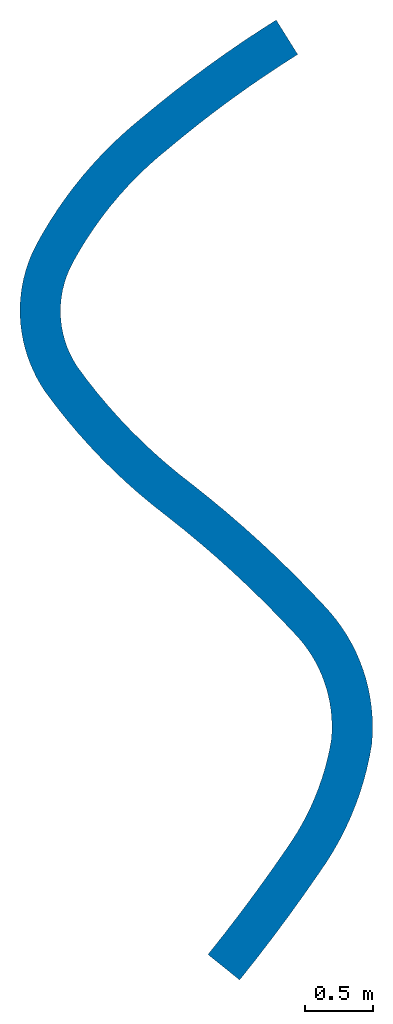
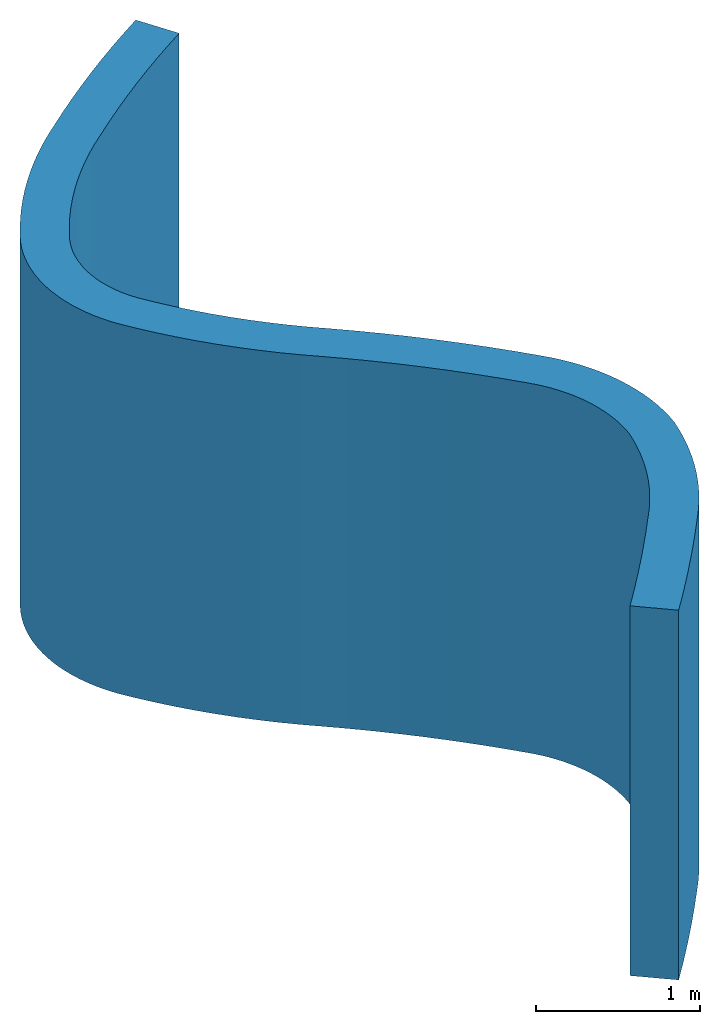
# Not in any storey: 1 wall.
"""IFC2X3 building model written with IfcOpenShell, lengths in metres."""

from ifc_helpers import new_model, si_unit, point, direction, frame, frame_2d, origin_with_axes, place, context, project, spatial, polyline, circle_curve, parameter, trimmed, segment, composite_curve, outline, extrude, material, layer, layer_set, layer_usage, type_object, element, save


model = new_model("IFC2X3")

# Units and contexts
model_context = context("Model", 3, precision=1e-05, world=origin_with_axes(), true_north=direction((0.0, 1.0)), identifier="Body")
ifc_project = project(units=[si_unit("LENGTHUNIT", "METRE"), si_unit("AREAUNIT", "SQUARE_METRE"), si_unit("VOLUMEUNIT", "CUBIC_METRE"), si_unit("PLANEANGLEUNIT", "RADIAN")], contexts=[model_context])

# Building
building_placement = place(None, origin_with_axes())
building = spatial("IfcBuilding", under=ifc_project, at=building_placement, CompositionType="ELEMENT")

# Wall
ifc_material = material(Name="Masonry")
ifc_layer = layer(ifc_material, 0.3, ventilated=True)
ifc_layer_set = layer_set([ifc_layer], Name="Masonry 300")
ifc_layer_usage = layer_usage(ifc_layer_set, "AXIS2", "NEGATIVE", -0.15)
wall_type = type_object("IfcWallType", Name="Masonry 300", PredefinedType="STANDARD", material=ifc_material)
wall_placement = place(None, frame((0.633000000001003, -0.205999999998753, 0.0), z_axis=(0.0, 0.0, 1.0), x_axis=(0.62704761, 0.77898094, 0.0)))
element("IfcWall", 1, at=wall_placement, inside=building, type_object=wall_type, material=ifc_layer_usage, context=model_context, shape_type="SweptSolid", body=[
    extrude(outline(composite_curve([segment(composite_curve([segment(trimmed(circle_curve(frame_2d((0.0, 12.5906721777929), x_axis=(0.0, -1.0)), 12.7406721777929), [parameter(0.0), point((0.0, -12.7406721777929))], [parameter(0.0779576017017681), point((0.992226509809783, -0.111304601244954))], True, "PARAMETER"), True, "CONTINUOUS"), segment(trimmed(circle_curve(frame_2d((0.858404826729998, 2.10421523903142), x_axis=(0.06029205, -0.99818078)), 2.21955770493145), [parameter(0.0), point((0.992226509809783, -2.21551984027638))], [parameter(0.461883740141353), point((1.96551768886992, 0.180485134259726))], True, "PARAMETER"), True, "CONTINUOUS")], self_intersect="UNKNOWN"), True, "CONTINUOUS"), segment(composite_curve([segment(composite_curve([segment(trimmed(circle_curve(frame_2d((1.24081001154631, 1.28335586960837), x_axis=(0.54915886, -0.83571798)), 1.31966854795446), [parameter(0.0), point((1.96551768886992, -1.10287073534864))], [parameter(0.210395964566149), point((2.17986805807303, 0.356158446341))], True, "PARAMETER"), True, "CONTINUOUS"), segment(trimmed(circle_curve(frame_2d((1.25166797507066, 1.27270454282025), x_axis=(0.71155965, -0.70262569)), 1.30445856241468), [parameter(0.0), point((2.17986805807303, -0.916546096479253))], [parameter(0.217081000384491), point((2.35548923034152, 0.577585288685234))], True, "PARAMETER"), True, "CONTINUOUS"), segment(trimmed(circle_curve(frame_2d((1.26571961381282, 1.26385603475642), x_axis=(0.846191, -0.53287972)), 1.28785300171339), [parameter(0.0), point((2.35548923034152, -0.686270746071181))], [parameter(0.218962834308345), point((2.47853899461762, 0.830688049366832))], True, "PARAMETER"), True, "CONTINUOUS"), segment(trimmed(circle_curve(frame_2d((1.27944446196939, 1.25890136073525), x_axis=(0.94175055, -0.3363122)), 1.27326130007158), [parameter(0.0), point((2.47853899461762, -0.428213311368416))], [parameter(0.215533275911176), point((2.54237621759732, 1.09704426670928))], True, "PARAMETER"), True, "CONTINUOUS")], self_intersect="UNKNOWN"), True, "CONTINUOUS"), segment(trimmed(circle_curve(frame_2d((-5.55050895259021, 2.28926282452048), x_axis=(0.98932235, -0.14574388)), 8.18023077103761), [parameter(0.0), point((2.54237621759732, -1.1922185578112))], [parameter(0.162755126513052), point((2.62860962012269, 2.42415107802535))], True, "PARAMETER"), True, "CONTINUOUS")], self_intersect="UNKNOWN"), True, "CONTINUOUS"), segment(composite_curve([segment(composite_curve([segment(trimmed(circle_curve(frame_2d((6.69562431221205, 2.53857517679835), x_axis=(-0.99276605, 0.12006484)), 4.06862401556727), [parameter(0.148482437366474), point((2.62860962012269, -0.114424098773002))], [parameter(0.0), point((2.65643250932397, 3.02707385594955))], False, "PARAMETER"), True, "CONTINUOUS"), segment(trimmed(circle_curve(frame_2d((6.67815815953575, 2.54068853966872), x_axis=(-0.96396513, 0.26602864)), 4.05103047155474), [parameter(0.148915910057531), point((2.65643250932397, 0.486385316280828))], [parameter(0.0), point((2.77310605905153, 3.6183786500292))], False, "PARAMETER"), True, "CONTINUOUS")], self_intersect="UNKNOWN"), True, "CONTINUOUS"), segment(trimmed(circle_curve(frame_2d((3.48219434932468, 3.39533102562583), x_axis=(-0.17757929, 0.9841065)), 0.743341406188621), [parameter(1.08751382659747), point((2.77310605905153, 0.223047624403365))], [parameter(0.0), point((3.3501923089331, 4.12685813208665))], False, "PARAMETER"), True, "CONTINUOUS")], self_intersect="UNKNOWN"), True, "CONTINUOUS"), segment(trimmed(circle_curve(frame_2d((3.84553509688989, 1.42371524424486), x_axis=(0.21751573, 0.97605682)), 2.74815318890168), [parameter(0.400504770798192), point((3.3501923089331, 2.70314288784179))], [parameter(0.0), point((4.4433016485376, 4.10606889344954))], False, "PARAMETER"), True, "CONTINUOUS"), segment(composite_curve([segment(trimmed(circle_curve(frame_2d((2.81851394213364, -4.20008417101934), x_axis=(0.26033035, 0.96551961)), 8.46357571132126), [parameter(0.0701910239030213), point((4.4433016485376, 8.30615306446888))], [parameter(0.0), point((5.02183957904783, 3.97166410942738))], False, "PARAMETER"), True, "CONTINUOUS"), segment(trimmed(circle_curve(frame_2d((2.84031506383951, -4.11924426569001), x_axis=(0.32784513, 0.94473148)), 8.37984770416501), [parameter(0.0706579165746258), point((5.02183957904783, 8.09090837511739))], [parameter(0.0), point((5.5876073216265, 3.79746166514406))], False, "PARAMETER"), True, "CONTINUOUS")], self_intersect="UNKNOWN"), True, "CONTINUOUS"), segment(polyline([(5.5876073216265, 3.79746166514406), (5.68597746420469, 4.08087534697531)]), True, "CONTINUOUS"), segment(composite_curve([segment(composite_curve([segment(trimmed(circle_curve(frame_2d((2.83955778650122, -4.12170794281741), x_axis=(0.327837, 0.9447343)), 8.68242348699971), [parameter(0.0), point((5.68597746420469, 8.20258328979272))], [parameter(0.0704156823942545), point((5.10181028065729, 4.26081502227424))], True, "PARAMETER"), True, "CONTINUOUS"), segment(trimmed(circle_curve(frame_2d((2.81798638223099, -4.20235808813424), x_axis=(0.26053477, 0.96546447)), 8.76590843528292), [parameter(0.0), point((5.10181028065729, 8.46317311040848))], [parameter(0.0699524375157497), point((4.5046879109871, 4.39974564575877))], True, "PARAMETER"), True, "CONTINUOUS")], self_intersect="UNKNOWN"), True, "CONTINUOUS"), segment(trimmed(circle_curve(frame_2d((3.8455356273326, 1.42370648390197), x_axis=(0.21624583, 0.97633895)), 3.04816187659912), [parameter(0.0), point((4.5046879109871, 2.9760391618568))], [parameter(0.399074273372537), point((3.29650622679579, 4.42201559793582))], True, "PARAMETER"), True, "CONTINUOUS"), segment(composite_curve([segment(trimmed(circle_curve(frame_2d((3.48010213034506, 3.40810517356184), x_axis=(-0.17817945, 0.98399801)), 1.03039885697448), [parameter(0.0), point((3.29650622679579, 1.01391042437399))], [parameter(0.270346117676781), point((3.03239471575158, 4.33615682911358))], True, "PARAMETER"), True, "CONTINUOUS"), segment(trimmed(circle_curve(frame_2d((3.48598078250791, 3.39613776733709), x_axis=(-0.43458104, 0.90063273)), 1.04373184125935), [parameter(0.0), point((3.03239471575158, 0.940019061776487))], [parameter(0.278361050439085), point((2.79155598268534, 4.17533630035035))], True, "PARAMETER"), True, "CONTINUOUS"), segment(trimmed(circle_curve(frame_2d((3.49676473529358, 3.38403407997117), x_axis=(-0.66532722, 0.74655186)), 1.05994272898694), [parameter(0.0), point((2.79155598268534, 0.791302220379178))], [parameter(0.275559056415503), point((2.60285980534036, 3.95360634486617))], True, "PARAMETER"), True, "CONTINUOUS"), segment(trimmed(circle_curve(frame_2d((3.50838196430836, 3.37651721255897), x_axis=(-0.8433037, 0.53743732)), 1.07377942195273), [parameter(0.0), point((2.60285980534036, 0.577089132307195))], [parameter(0.263140403514809), point((2.48392076033443, 3.69820260010621))], True, "PARAMETER"), True, "CONTINUOUS")], self_intersect="UNKNOWN"), True, "CONTINUOUS")], self_intersect="UNKNOWN"), True, "CONTINUOUS"), segment(composite_curve([segment(composite_curve([segment(trimmed(circle_curve(frame_2d((6.67814622326416, 2.54069120373496), x_axis=(-0.96396412, 0.2660323)), 4.35101825629558), [parameter(0.0), point((2.48392076033443, 1.15751139637125))], [parameter(0.14871027942696), point((2.35871237809326, 3.06399907087401))], True, "PARAMETER"), True, "CONTINUOUS"), segment(trimmed(circle_curve(frame_2d((6.69558814572964, 2.5385771433756), x_axis=(-0.99274089, 0.12027272)), 4.36858782970055), [parameter(0.0), point((2.35871237809326, 0.525421927498412))], [parameter(0.148280353735435), point((2.32867810374149, 2.417513891351))], True, "PARAMETER"), True, "CONTINUOUS")], self_intersect="UNKNOWN"), True, "CONTINUOUS"), segment(composite_curve([segment(trimmed(circle_curve(frame_2d((-5.53722086560982, 2.29018971445617), x_axis=(0.99786202, -0.0653559)), 7.8669293909418), [parameter(0.081587954383697), point((2.32867810374149, 0.127324176894835))], [parameter(0.0), point((2.31288917194865, 1.77603950266238))], False, "PARAMETER"), True, "CONTINUOUS"), segment(trimmed(circle_curve(frame_2d((-5.64214815642544, 2.29705402330002), x_axis=(0.98932158, -0.14574913)), 7.97208097215153), [parameter(0.0808686387395047), point((2.31288917194865, -0.521014520637636))], [parameter(0.0), point((2.24480359373925, 1.13513013718928))], False, "PARAMETER"), True, "CONTINUOUS")], self_intersect="UNKNOWN"), True, "CONTINUOUS")], self_intersect="UNKNOWN"), True, "CONTINUOUS"), segment(composite_curve([segment(composite_curve([segment(trimmed(circle_curve(frame_2d((1.27950974863352, 1.2588883080951), x_axis=(0.94248197, -0.33425699)), 0.973194889148593), [parameter(0.213304607056117), point((2.24480359373925, -0.12375817090581))], [parameter(0.0), point((2.19672838578957, 0.933591114872435))], False, "PARAMETER"), True, "CONTINUOUS"), segment(trimmed(circle_curve(frame_2d((1.26594460088601, 1.26375079203904), x_axis=(0.84853767, -0.52913497)), 0.987605116767915), [parameter(0.216714878696181), point((2.19672838578957, -0.330159677166606))], [parameter(0.0), point((2.10396474631296, 0.741174383726576))], False, "PARAMETER"), True, "CONTINUOUS"), segment(trimmed(circle_curve(frame_2d((1.25200029259022, 1.27244616790671), x_axis=(0.71613222, -0.69796464)), 1.0040384151381), [parameter(0.214970646318693), point((2.10396474631296, -0.531271784180138))], [parameter(0.0), point((1.97102455457684, 0.571662856356253))], False, "PARAMETER"), True, "CONTINUOUS"), segment(trimmed(circle_curve(frame_2d((1.24111797301021, 1.28298529850649), x_axis=(0.55614796, -0.83108329)), 1.0191875364823), [parameter(0.208548481379479), point((1.97102455457684, -0.711322442150237))], [parameter(0.0), point((1.80793704571323, 0.435955562699688))], False, "PARAMETER"), True, "CONTINUOUS")], self_intersect="UNKNOWN"), True, "CONTINUOUS"), segment(composite_curve([segment(trimmed(circle_curve(frame_2d((0.865464974174703, 2.0921263494107), x_axis=(0.39166325, -0.92010864)), 1.90555904668029), [parameter(0.114925447323616), point((1.80793704571324, -1.65617078671101))], [parameter(0.0), point((1.61180241808548, 0.338805015427155))], False, "PARAMETER"), True, "CONTINUOUS"), segment(trimmed(circle_curve(frame_2d((0.858778212823704, 2.10785247811792), x_axis=(0.28351238, -0.95896858)), 1.92264775217999), [parameter(0.114980228431338), point((1.61180241808548, -1.76904746269077))], [parameter(0.0), point((1.40387264694797, 0.264093698654212))], False, "PARAMETER"), True, "CONTINUOUS"), segment(trimmed(circle_curve(frame_2d((0.853767680723008, 2.12479514090241), x_axis=(0.1723241, -0.98504031)), 1.94031578127115), [parameter(0.114266986281034), point((1.40387264694797, -1.86070144224819))], [parameter(0.0), point((1.18813084735411, 0.213505889153654))], False, "PARAMETER"), True, "CONTINUOUS"), segment(trimmed(circle_curve(frame_2d((0.850791973837679, 2.14174954891179), x_axis=(0.06031631, -0.99817931)), 1.95752934255985), [parameter(0.112840513314093), point((1.18813084735411, -1.92824365975814))], [parameter(0.0), point((0.968862911030296, 0.187784252195076))], False, "PARAMETER"), True, "CONTINUOUS")], self_intersect="UNKNOWN"), True, "CONTINUOUS")], self_intersect="UNKNOWN"), True, "CONTINUOUS"), segment(trimmed(circle_curve(frame_2d((0.0, 12.5906721777929), x_axis=(0.0, -1.0)), 12.4406721777929), [parameter(0.0779576017017678), point((0.968862911030296, -12.4028879255979))], [parameter(0.0), point((0.0, 0.149999999999997))], False, "PARAMETER"), True, "CONTINUOUS"), segment(polyline([(0.0, 0.149999999999998), (0.0, -0.150000000000002)]), True, "CONTINUOUS")], self_intersect="UNKNOWN")), origin_with_axes(), (0.0, 0.0, 1.0), 2.75),
])

save(model, "model.ifc")
